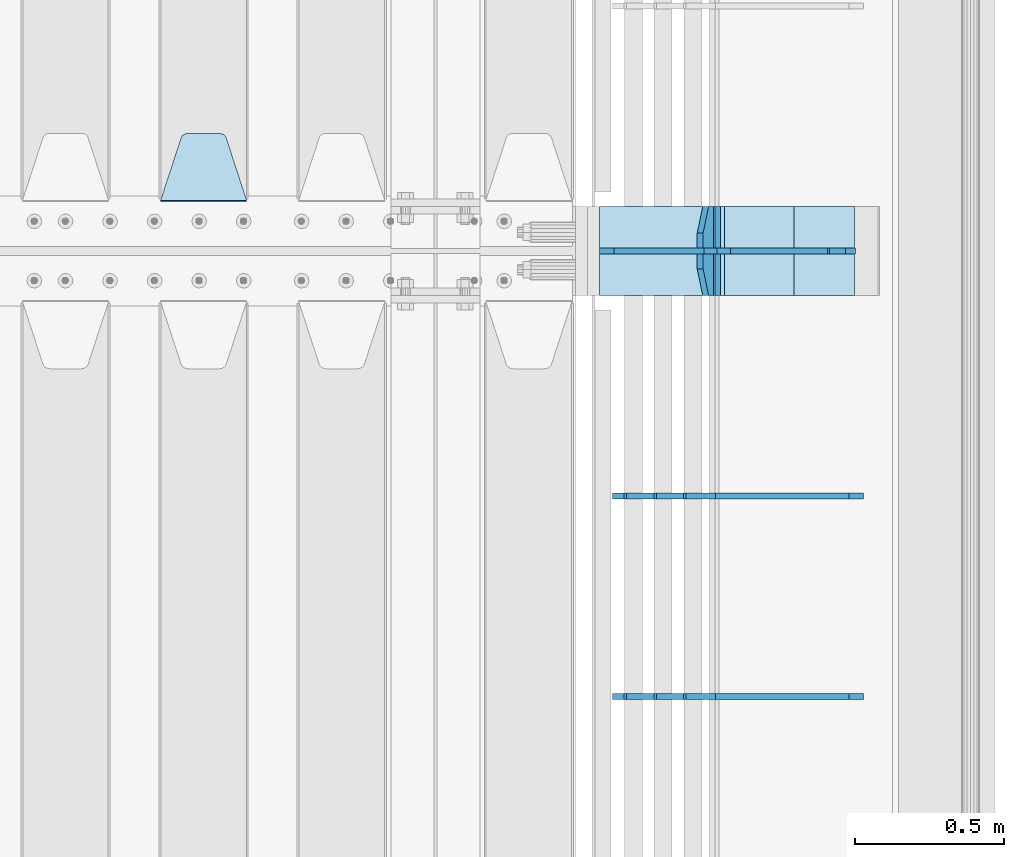
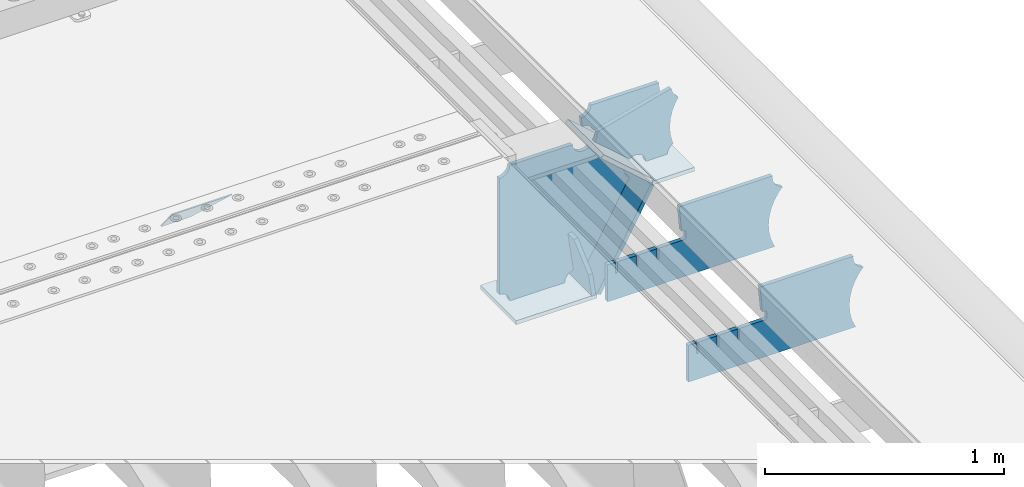
# One storey, part 240 of 257: 11 plates.
"""IFC2X3 building model written with IfcOpenShell, lengths in millimetres."""

from ifc_helpers import new_model, si_unit, frame, origin_with_axes, place, context, subcontext, project, spatial, faceted_brep, material, type_object, element, save


model = new_model("IFC2X3")

# Units and contexts
model_context = context("Model", 3, precision=1e-05, world=origin_with_axes())
body_context = subcontext(model_context, "Body", "Model", "MODEL_VIEW")
ifc_project = project(units=[si_unit("LENGTHUNIT", "METRE", prefix="MILLI"), si_unit("AREAUNIT", "SQUARE_METRE"), si_unit("VOLUMEUNIT", "CUBIC_METRE"), si_unit("MASSUNIT", "GRAM", prefix="KILO"), si_unit("TIMEUNIT", "SECOND"), si_unit("PLANEANGLEUNIT", "RADIAN"), si_unit("SOLIDANGLEUNIT", "STERADIAN"), si_unit("THERMODYNAMICTEMPERATUREUNIT", "DEGREE_CELSIUS"), si_unit("LUMINOUSINTENSITYUNIT", "LUMEN")], contexts=[model_context])

# Site, building, storey
site_placement = place(None, origin_with_axes())
site = spatial("IfcSite", under=ifc_project, at=site_placement, CompositionType="ELEMENT")
building_placement = place(site_placement, origin_with_axes())
building = spatial("IfcBuilding", under=site, at=building_placement, Name="Standard", CompositionType="ELEMENT")
storey_placement = place(building_placement, origin_with_axes())
storey = spatial("IfcBuildingStorey", under=building, at=storey_placement, Name="Undefined", CompositionType="ELEMENT", Elevation=0.0)

# Plates
ifc_material = material(Name="STEEL/S355N")
plate_type_1 = type_object("IfcPlateType", PredefinedType="NOTDEFINED")
plate_1_placement = place(storey_placement, frame((58160.0, 9168.23223304703, -1.76776695296758), z_axis=(0.0, 0.707106781186547, -0.707106781186548), x_axis=(-1.0, 0.0, 0.0)))
element("IfcPlate", 1, at=plate_1_placement, inside=storey, type_object=plate_type_1, material=ifc_material, context=body_context, shape_type="Brep", body=[
    faceted_brep([(0.0, -2.5, 0.0), (69.345504679477, -2.50000000000091, 300.17173142483), (69.345504679477, 2.5, 300.171731424831), (0.0, 2.5, 0.0), (70.927406119954, -2.50000000000091, 304.8974424154), (70.927406119954, 2.5, 304.8974424154), (73.3818627772271, -2.50000000000091, 309.234538108527), (73.3818627772271, 2.49999999999909, 309.234538108527), (76.6187032999587, -2.5, 313.023683126103), (76.6187032999587, 2.5, 313.023683126103), (80.5190132705029, -2.5, 316.125672595372), (80.5190132705029, 2.5, 316.125672595371), (84.9395038596849, -2.5, 318.426546230476), (84.9395038596849, 2.5, 318.426546230477), (89.7177759439219, -2.5, 319.841774983275), (89.7177759439219, 2.5, 319.841774983275), (94.6782862926484, -2.5, 320.319366455079), (94.6782862926484, 2.5, 320.319366455079), (195.321713707352, -2.5, 320.319366455079), (195.321713707352, 2.5, 320.319366455079), (200.282224056078, -2.5, 319.841774983275), (200.282224056078, 2.49999999999909, 319.841774983275), (205.060496140315, -2.5, 318.426546230476), (205.060496140315, 2.49999999999909, 318.426546230475), (209.480986729497, -2.5, 316.125672595371), (209.480986729497, 2.5, 316.125672595371), (213.381296700041, -2.50000000000091, 313.023683126102), (213.381296700041, 2.5, 313.023683126103), (216.618137222766, -2.50000000000091, 309.234538108527), (216.618137222766, 2.5, 309.234538108527), (219.072593880039, -2.5, 304.897442415399), (219.072593880039, 2.5, 304.897442415399), (220.654495320523, -2.50000000000091, 300.17173142483), (220.654495320523, 2.5, 300.171731424831), (290.0, -2.50000000000091, 0.0), (290.0, 2.5, 9.09494701772928e-13)], [[[0, 1, 2, 3]], [[1, 4, 5, 2]], [[4, 6, 7, 5]], [[6, 8, 9, 7]], [[8, 10, 11, 9]], [[10, 12, 13, 11]], [[12, 14, 15, 13]], [[14, 16, 17, 15]], [[16, 18, 19, 17]], [[18, 20, 21, 19]], [[20, 22, 23, 21]], [[22, 24, 25, 23]], [[24, 26, 27, 25]], [[26, 28, 29, 27]], [[28, 30, 31, 29]], [[30, 32, 33, 31]], [[32, 34, 35, 33]], [[34, 0, 3, 35]], [[5, 7, 9, 11, 13, 15, 17, 19, 21, 23, 25, 27, 29, 31, 33, 35, 3, 2]], [[34, 32, 30, 28, 26, 24, 22, 20, 18, 16, 14, 12, 10, 8, 6, 4, 1, 0]]]),
])
plate_type_2 = type_object("IfcPlateType", PredefinedType="NOTDEFINED")
plate_2_placement = place(storey_placement, frame((59721.0775331946, 9150.00000000169, -871.412303810021), z_axis=(0.0, -1.0, 0.0), x_axis=(-0.137902988002477, 0.0, 0.990445741017643)))
element("IfcPlate", 2, at=plate_2_placement, inside=storey, type_object=plate_type_2, material=ifc_material, context=body_context, shape_type="Brep", body=[
    faceted_brep([(0.0, -10.0, 0.0), (-2.00088834390044e-10, -10.0, 300.0), (-2.00088834390044e-10, 10.0, 300.0), (0.0, 10.0, 0.0), (114.999999999998, -10.0, 300.0), (115.0, 10.0, 300.0), (249.999999999998, -10.0, 210.0), (249.999999999998, 10.0, 210.0), (249.999999999998, -10.0, 90.0), (249.999999999998, 10.0, 90.0), (114.999999999998, -10.0, -1.10503606265411e-10), (115.0, 10.0, -1.10503606265411e-10)], [[[0, 1, 2, 3]], [[1, 4, 5, 2]], [[4, 6, 7, 5]], [[6, 8, 9, 7]], [[8, 10, 11, 9]], [[10, 0, 3, 11]], [[5, 7, 9, 11, 3, 2]], [[10, 8, 6, 4, 1, 0]]]),
])
plate_type_3 = type_object("IfcPlateType", PredefinedType="NOTDEFINED")
plate_3_placement = place(storey_placement, frame((59749.9988298913, 9000.00000000007, -179.999999999866), z_axis=(0.0, 0.0, -1.0), x_axis=(-1.0, 0.0, 0.0)))
element("IfcPlate", 3, at=plate_3_placement, inside=storey, type_object=plate_type_3, material=ifc_material, context=body_context, shape_type="Brep", body=[
    faceted_brep([(46.0258547361809, 10.0, 641.078828352491), (73.3015011075258, 10.0, 445.179898435806), (73.3015011075258, -10.0, 445.179898435806), (46.0258547361809, -10.0, 641.078828352491), (53.4925862871751, 10.0, 442.421838675757), (53.4925862871751, -10.0, 442.421838675757), (25.7820501124297, 10.0, 641.4442306713), (25.7820501124297, -10.0, 641.4442306713), (54.6652503111691, 10.0, 642.447174185377), (54.6652503111691, -10.0, 642.447174185377), (68.6036632070463, -10.0, 649.549150281387), (68.6036632070463, 10.0, 649.549150281387), (79.6652503111691, -10.0, 660.610737385511), (79.6652503111691, 10.0, 660.610737385511), (86.7672264071807, -10.0, 674.549150281387), (86.7672264071807, 10.0, 674.549150281387), (89.2144005924201, -10.0, 690.0), (89.2144005924201, 10.0, 690.0), (353.0, -10.0, 690.0), (353.0, 10.0, 690.0), (355.447174185239, -10.0, 674.549150281253), (355.447174185239, 10.0, 674.549150281253), (362.549150281251, -10.0, 660.610737385376), (362.549150281251, 10.0, 660.610737385376), (373.610737385374, -10.0, 649.549150281253), (373.610737385374, 10.0, 649.549150281253), (387.549150281251, -10.0, 642.447174185242), (387.549150281251, 10.0, 642.447174185242), (403.0, -10.0, 640.0), (403.0, 10.0, 640.0), (403.0, -10.0, 50.0), (403.0, 10.0, 50.0), (387.549150281251, -10.0, 47.5528258147577), (387.549150281251, 10.0, 47.5528258147577), (373.610737385374, -10.0, 40.4508497187474), (373.610737385374, 10.0, 40.4508497187474), (362.549150281251, -10.0, 29.3892626146236), (362.549150281251, 10.0, 29.3892626146236), (355.447174185239, -10.0, 15.4508497187474), (355.447174185239, 10.0, 15.4508497187474), (353.0, -10.0, 0.0), (353.0, 10.0, 0.0), (50.0, -10.0, 0.0), (50.0, 10.0, 0.0), (47.0349915316328, -10.0, 16.9620037619133), (47.0349915316328, 10.0, 16.9620037619133), (38.4916171352306, -10.0, 31.9123081320451), (38.4916171352306, 10.0, 31.9123081320451), (25.3831239081483, -10.0, 43.0778019479116), (25.3831239081483, 10.0, 43.0778019479116), (9.26418358741648, -10.0, 49.1342538608113), (9.26418358741648, 10.0, 49.1342538608113), (-7.95349204488593, -10.0, 49.363366622344), (-7.95349204488593, 10.0, 49.363366622344), (-24.2278808265401, -10.0, 43.7379673813837), (-24.2278808265401, 10.0, 43.7379673813837), (-37.6288347353475, -10.0, 32.9252303934259), (-37.6288347353475, 10.0, 32.9252303934259), (-210.371165264653, -10.0, 184.074769606574), (-210.371165264653, 10.0, 184.074769606574), (-202.382363280565, -10.0, 196.529747922069), (-202.382363280565, 10.0, 196.529747922069), (-198.388707244048, -10.0, 210.777489969227), (-198.388707244048, 10.0, 210.777489969227), (-198.73995746443, -10.0, 225.570193077959), (-198.73995746443, 10.0, 225.570193077959), (-203.40535180681, -10.0, 239.612327446012), (-203.40535180681, 10.0, 239.612327446012), (-211.976299808361, -10.0, 251.674097313455), (-211.976299808361, 10.0, 251.674097313455), (-223.702166612966, -10.0, 260.699145216992), (-223.702166612966, 10.0, 260.699145216992), (-9.29783338703419, -10.0, 646.300854783008), (-9.29783338703419, 10.0, 646.300854783008), (6.98069453598146, -10.0, 640.647282345602), (6.98069453598146, 10.0, 640.647282345602), (24.2117663163663, -10.0, 640.855891896051), (24.2117663163663, 10.0, 640.855891896051)], [[[0, 1, 2, 3]], [[4, 5, 2, 1]], [[6, 7, 5, 4]], [[8, 9, 10, 11]], [[11, 10, 12, 13]], [[13, 12, 14, 15]], [[15, 14, 16, 17]], [[18, 19, 17, 16]], [[18, 20, 21, 19]], [[20, 22, 23, 21]], [[22, 24, 25, 23]], [[24, 26, 27, 25]], [[26, 28, 29, 27]], [[28, 30, 31, 29]], [[30, 32, 33, 31]], [[32, 34, 35, 33]], [[34, 36, 37, 35]], [[36, 38, 39, 37]], [[38, 40, 41, 39]], [[40, 42, 43, 41]], [[42, 44, 45, 43]], [[44, 46, 47, 45]], [[46, 48, 49, 47]], [[48, 50, 51, 49]], [[50, 52, 53, 51]], [[52, 54, 55, 53]], [[54, 56, 57, 55]], [[56, 58, 59, 57]], [[58, 60, 61, 59]], [[60, 62, 63, 61]], [[62, 64, 65, 63]], [[64, 66, 67, 65]], [[66, 68, 69, 67]], [[68, 70, 71, 69]], [[70, 72, 73, 71]], [[72, 74, 75, 73]], [[74, 76, 77, 75]], [[1, 0, 8, 11, 13, 15, 17, 19, 21, 23, 25, 27, 29, 31, 33, 35, 37, 39, 41, 43, 45, 47, 49, 51, 53, 55, 57, 59, 61, 63, 65, 67, 69, 71, 73, 75, 77, 6, 4]], [[9, 8, 0, 3]], [[76, 74, 72, 70, 68, 66, 64, 62, 60, 58, 56, 54, 52, 50, 48, 46, 44, 42, 40, 38, 36, 34, 32, 30, 28, 26, 24, 22, 20, 18, 16, 14, 12, 10, 9, 3, 2, 5, 7]], [[77, 76, 7, 6]]]),
])
plate_type_4 = type_object("IfcPlateType", PredefinedType="NOTDEFINED")
plate_4_placement = place(storey_placement, frame((60285.9988298906, 9000.0, -9.99999999999716), z_axis=(0.0, 0.0, -1.0), x_axis=(-1.0, 0.0, 0.0)))
element("IfcPlate", 4, at=plate_4_placement, inside=storey, type_object=plate_type_4, material=ifc_material, context=body_context, shape_type="Brep", body=[
    faceted_brep([(164.157641141064, -10.0, 44.1844865875018), (486.71834084086, -10.0, 131.004562768382), (486.71834084086, 10.0, 131.004562768382), (164.157641141064, 10.0, 44.1844865875018), (492.179177700767, -10.0, 118.185717565315), (492.179177700767, 10.0, 118.185717565315), (500.965368826706, -10.0, 107.371542744776), (500.965368826706, 10.0, 107.371542744776), (512.394601349042, -10.0, 99.4018391429503), (512.394601349042, 10.0, 99.4018391429503), (525.579310641864, -10.0, 94.8955133209048), (525.579310641864, 10.0, 94.8955133209048), (539.495606295335, -10.0, 94.2025148824028), (539.495606295335, 10.0, 94.2025148824028), (543.504393704665, -10.0, 49.7974851175972), (543.504393704665, 10.0, 49.7974851175972), (529.167086307512, -10.0, 46.3176139481669), (529.167086307512, 10.0, 46.3176139481669), (516.469507120331, -10.0, 38.8049999196639), (516.469507120331, 10.0, 38.8049999196639), (506.517198234542, -10.0, 27.9137449599276), (506.517198234542, 10.0, 27.9137449599276), (500.17667886756, -10.0, 14.592119649441), (500.17667886756, 10.0, 14.592119649441), (498.0, -10.0, 0.0), (498.0, 10.0, 0.0), (170.0, -10.0, 0.0), (170.0, 10.0, 0.0), (169.632873911985, -10.0, 11.1663820622718), (169.632873911985, 10.0, 11.1663820622718), (168.533081313406, -10.0, 22.2845350637931), (168.533081313406, 10.0, 22.2845350637931), (166.705372351957, -10.0, 33.3064382514178), (166.705372351957, 10.0, 33.3064382514178)], [[[0, 1, 2, 3]], [[1, 4, 5, 2]], [[4, 6, 7, 5]], [[6, 8, 9, 7]], [[8, 10, 11, 9]], [[10, 12, 13, 11]], [[12, 14, 15, 13]], [[14, 16, 17, 15]], [[16, 18, 19, 17]], [[18, 20, 21, 19]], [[20, 22, 23, 21]], [[22, 24, 25, 23]], [[24, 26, 27, 25]], [[26, 28, 29, 27]], [[28, 30, 31, 29]], [[30, 32, 33, 31]], [[32, 0, 3, 33]], [[5, 7, 9, 11, 13, 15, 17, 19, 21, 23, 25, 27, 29, 31, 33, 3, 2]], [[32, 30, 28, 26, 24, 22, 20, 18, 16, 14, 12, 10, 8, 6, 4, 1, 0]]]),
])
plate_type_5 = type_object("IfcPlateType", PredefinedType="NOTDEFINED")
plate_5_placement = place(storey_placement, frame((60290.9988502512, 8999.99999999933, -28.9999913318487), z_axis=(0.260769276985653, 0.0, -0.965401151946889), x_axis=(-0.965401151946889, 0.0, -0.260769276985654)))
element("IfcPlate", 5, at=plate_5_placement, inside=storey, type_object=plate_type_5, material=ifc_material, context=body_context, shape_type="Brep", body=[
    faceted_brep([(183.436474692309, 10.0, 275.852500330426), (184.918388609047, 10.0, 264.417843531332), (184.918388609047, -10.0, 264.417843531332), (183.436474692309, -10.0, 275.852500330426), (183.794583267605, 10.0, 224.576469334614), (183.794583267605, -10.0, 224.576469334614), (176.452049775828, 10.0, 185.401410454628), (176.452049775828, -10.0, 185.401410454628), (163.071585676764, 10.0, 147.857286855564), (163.071585676764, -10.0, 147.857286855564), (143.982662403738, 10.0, 112.868559462235), (143.982662403738, -10.0, 112.868559462235), (119.65531260024, 10.0, 81.2967668639885), (119.65531260024, -10.0, 81.2967668639885), (100.960891712741, 10.0, 63.6280409830997), (100.960891712741, -10.0, 63.6280409830997), (194.486836975899, -10.0, 278.751956446691), (207.178624553366, -10.0, 286.65099493752), (207.178624553366, 10.0, 286.65099493752), (194.486836975899, 10.0, 278.751956446691), (216.968013469435, -10.0, 297.948965801401), (216.968013469435, 10.0, 297.948965801401), (222.979925232852, -10.0, 311.635937633771), (222.979925232852, 10.0, 311.635937633771), (323.381647032758, -10.0, 284.515917834988), (323.381647032758, 10.0, 284.515917834988), (321.720617177329, -10.0, 268.853198956864), (321.720617177329, 10.0, 268.853198956864), (325.01434448114, -10.0, 253.450889283185), (325.01434448114, 10.0, 253.450889283185), (332.935986082477, -10.0, 239.837389469556), (332.935986082477, 10.0, 239.837389469556), (344.699462330085, -10.0, 229.36359314694), (344.699462330085, 10.0, 229.36359314694), (359.1374609708, -10.0, 223.068835162203), (359.1374609708, 10.0, 223.068835162203), (374.817271777676, -10.0, 221.577756392893), (374.817271777676, 10.0, 221.577756392893), (390.182952880852, -10.0, 225.03833007813), (390.182952880852, 10.0, 225.03833007813), (512.909060513019, -10.0, 41.5599003357038), (512.909060513019, 10.0, 41.5599003357038), (503.648024844573, -10.0, 33.5643666747728), (503.648024844573, 10.0, 33.5643666747728), (496.6060645697, -10.0, 23.5590612990018), (496.6060645697, 10.0, 23.5590612990018), (492.204839143924, -10.0, 12.1430832451115), (492.204839143924, 10.0, 12.1430832451115), (490.707885742188, -10.0, 3.83806764148176e-10), (490.707885742188, 10.0, 3.83806764148176e-10), (119.999999999993, -10.0, 9.64064383879304e-11), (119.999999999993, 10.0, 9.64064383879304e-11), (117.226254779103, -10.0, 25.6516118492182), (117.226254779103, 10.0, 25.6516118492182), (109.033246825653, -10.0, 50.1173731021008), (109.033246825653, 10.0, 50.1173731021008)], [[[0, 1, 2, 3]], [[4, 5, 2, 1]], [[6, 7, 5, 4]], [[8, 9, 7, 6]], [[10, 11, 9, 8]], [[12, 13, 11, 10]], [[14, 15, 13, 12]], [[16, 17, 18, 19]], [[17, 20, 21, 18]], [[20, 22, 23, 21]], [[22, 24, 25, 23]], [[24, 26, 27, 25]], [[26, 28, 29, 27]], [[28, 30, 31, 29]], [[30, 32, 33, 31]], [[32, 34, 35, 33]], [[34, 36, 37, 35]], [[36, 38, 39, 37]], [[38, 40, 41, 39]], [[40, 42, 43, 41]], [[42, 44, 45, 43]], [[44, 46, 47, 45]], [[46, 48, 49, 47]], [[48, 50, 51, 49]], [[50, 52, 53, 51]], [[52, 54, 55, 53]], [[10, 8, 6, 4, 1, 0, 19, 18, 21, 23, 25, 27, 29, 31, 33, 35, 37, 39, 41, 43, 45, 47, 49, 51, 53, 55, 14, 12]], [[16, 19, 0, 3]], [[54, 52, 50, 48, 46, 44, 42, 40, 38, 36, 34, 32, 30, 28, 26, 24, 22, 20, 17, 16, 3, 2, 5, 7, 9, 11, 13, 15]], [[55, 54, 15, 14]]]),
])
plate_type_6 = type_object("IfcPlateType", PredefinedType="NOTDEFINED")
plate_6_placement = place(storey_placement, frame((59762.2260590443, 9149.99999999933, -177.219372761326), z_axis=(0.752414935148685, 0.0, -0.658689430130164), x_axis=(0.0, -1.0, 0.0)))
element("IfcPlate", 6, at=plate_6_placement, inside=storey, type_object=plate_type_6, material=ifc_material, context=body_context, shape_type="Brep", body=[
    faceted_brep([(0.0, -10.0, 0.0), (1.09139364212751e-10, -10.0000000000146, 319.999999999993), (1.09139364212751e-10, 9.99999999999272, 320.0), (0.0, 10.0, 0.0), (300.0, -10.0000000000146, 319.999999999993), (300.0, 9.99999999999272, 320.0), (300.0, -10.0000000000073, 5.82076609134674e-11), (300.0, 9.99999999999272, 5.82076609134674e-11)], [[[0, 1, 2, 3]], [[1, 4, 5, 2]], [[4, 6, 7, 5]], [[6, 0, 3, 7]], [[5, 7, 3, 2]], [[6, 4, 1, 0]]]),
])
plate_7_placement = place(storey_placement, frame((60003.0007288108, 9150.00000000007, -408.004820491625), z_axis=(-0.484064236150485, 0.0, -0.875032465272031), x_axis=(0.0, -1.0, 0.0)))
element("IfcPlate", 7, at=plate_7_placement, inside=storey, type_object=plate_type_6, material=ifc_material, context=body_context, shape_type="Brep", body=[
    faceted_brep([(0.0, -10.0, 0.0), (3.86515239370056e-07, -10.0, 533.528442382816), (3.86515239370056e-07, 10.0, 533.528442382813), (0.0, 10.0, 0.0), (300.003295898438, -10.0, 533.549133300781), (300.003295898438, 10.0, 533.549133300785), (300.0, -10.0000000000073, 5.82076609134674e-11), (300.0, 9.99999999999272, 5.82076609134674e-11)], [[[0, 1, 2, 3]], [[1, 4, 5, 2]], [[4, 6, 7, 5]], [[6, 0, 3, 7]], [[5, 7, 3, 2]], [[6, 4, 1, 0]]]),
])
plate_8_placement = place(storey_placement, frame((59346.9988298913, 9150.00000000007, -879.999999999866), z_axis=(0.0, -1.0, 0.0), x_axis=(1.0, 0.0, 0.0)))
element("IfcPlate", 8, at=plate_8_placement, inside=storey, type_object=plate_type_6, material=ifc_material, context=body_context, shape_type="Brep", body=[
    faceted_brep([(0.0, -10.0, 0.0), (-2.00088834390044e-10, -10.0, 300.0), (-2.00088834390044e-10, 10.0, 300.0), (0.0, 10.0, 0.0), (389.0, -10.0, 300.0), (389.0, 10.0, 300.0), (389.0, -10.0, 0.0), (389.0, 10.0, 0.0)], [[[0, 1, 2, 3]], [[1, 4, 5, 2]], [[4, 6, 7, 5]], [[6, 0, 3, 7]], [[5, 7, 3, 2]], [[6, 4, 1, 0]]]),
])
plate_type_7 = type_object("IfcPlateType", PredefinedType="NOTDEFINED")
plate_9_placement = place(storey_placement, frame((60206.9988298913, 9149.99999999933, -397.999999999763), z_axis=(-1.0, 0.0, 0.0), x_axis=(0.0, -1.0, 0.0)))
element("IfcPlate", 9, at=plate_9_placement, inside=storey, type_object=plate_type_7, material=ifc_material, context=body_context, shape_type="Brep", body=[
    faceted_brep([(0.0, -10.0, 0.0), (4.63842297904193e-10, -10.0, 204.0), (4.63842297904193e-10, 10.0, 204.0), (0.0, 10.0, 0.0), (300.0, -10.0, 204.0), (300.0, 10.0, 204.0), (300.0, -10.0000000000073, 5.82076609134674e-11), (300.0, 9.99999999999272, 5.82076609134674e-11)], [[[0, 1, 2, 3]], [[1, 4, 5, 2]], [[4, 6, 7, 5]], [[6, 0, 3, 7]], [[5, 7, 3, 2]], [[6, 4, 1, 0]]]),
])
plate_type_8 = type_object("IfcPlateType", PredefinedType="NOTDEFINED")
plate_10_placement = place(storey_placement, frame((60232.9182339676, 7499.99928283691, -374.002067436517), z_axis=(0.0, 0.0, 1.0), x_axis=(-1.0, 0.0, 0.0)))
element("IfcPlate", 10, at=plate_10_placement, inside=storey, type_object=plate_type_8, material=ifc_material, context=body_context, shape_type="Brep", body=[
    faceted_brep([(801.919404066546, -10.0, 188.0), (801.919404066546, 10.0, 188.0), (801.919404066546, 10.0, 132.002067436952), (801.919404066546, -10.0, 132.002067436952), (793.919404066546, 10.0, 132.002067436952), (793.919404066546, -10.0, 132.002067436952), (793.919404066546, 10.0, 180.002067436952), (793.919404066546, -10.0, 180.002067436952), (793.52785619691, 10.0, 182.474203391951), (793.52785619691, -10.0, 182.474203391951), (792.391540021548, 10.0, 184.704349455291), (792.391540021548, -10.0, 184.704349455291), (790.621686084887, 10.0, 186.474203391951), (790.621686084887, -10.0, 186.474203391951), (788.391540021548, 10.0, 187.610519567313), (788.391540021548, -10.0, 187.610519567313), (785.919404066546, -10.0, 188.002067436952), (785.919404066546, 10.0, 188.0), (841.0, -10.0, 188.0), (841.0, -10.0, 0.0), (841.0, 10.0, 0.0), (841.0, 10.0, 188.0), (33.3619566735943, -10.0, 0.0), (33.3619566735943, 10.0, 0.0), (36.2350612208102, -10.0, 4.68848050267013), (36.2350612208102, 10.0, 4.68848050267013), (51.4877592159319, -10.0, 41.5117508652784), (51.4877592159319, 10.0, 41.5117508652784), (60.7922425881334, -10.0, 80.2677133162964), (60.7922425881334, 10.0, 80.2677133162964), (63.9194040769653, -10.0, 120.002067436515), (63.9194040769653, 10.0, 120.002067436515), (60.7922425881334, -10.0, 159.736421556734), (60.7922425881334, 10.0, 159.736421556734), (51.4877592159319, -10.0, 198.492384007752), (51.4877592159319, 10.0, 198.492384007752), (36.2350612208102, -10.0, 235.31565437036), (36.2350612208102, 10.0, 235.31565437036), (15.4097206482038, -10.0, 269.299521518803), (15.4097206482038, 10.0, 269.299521518803), (-3.35474438100209, -10.0, 291.269887256574), (-3.35474438100209, 10.0, 291.269887256574), (-2.36881039375294, -10.0000000000001, 291.426043859339), (-2.36881039375294, 10.0, 291.426043859339), (17.1449676604752, -10.0000000000001, 301.368810393754), (17.1449676604752, 10.0, 301.368810393754), (32.6311896062471, -10.0000000000001, 316.855032339527), (32.6311896062471, 10.0, 316.855032339527), (42.573956140659, -10.0000000000001, 336.368810393754), (42.573956140659, 10.0, 336.368810393754), (46.0, -10.0000000000001, 358.0), (46.0, 10.0, 358.0), (45.0495205499174, -10.0, 364.001091067617), (45.0495205499174, 10.0, 364.001091067617), (495.040008544922, -10.0, 364.010009765625), (495.040008544922, 10.0, 364.010009765625), (483.600036621094, -10.0, 233.759994506836), (483.600036621094, 10.0, 233.759994506836), (472.0, -10.0, 233.759994506836), (472.0, 10.0, 233.759994506836), (468.909830056247, -10.0, 233.270559669787), (468.909830056247, 10.0, 233.270559669787), (466.122147477072, -10.0, 231.850164450585), (466.122147477072, 10.0, 231.850164450585), (463.909830056247, -10.0, 229.637847029761), (463.909830056247, 10.0, 229.637847029761), (462.489434837051, -10.0, 226.850164450585), (462.489434837051, 10.0, 226.850164450585), (462.0, -10.0, 223.759994506836), (462.0, 10.0, 223.759994506836), (462.0, -10.0, 198.0), (462.0, 10.0, 198.0), (462.489434837051, -10.0, 194.909830056251), (462.489434837051, 10.0, 194.909830056251), (463.909830056247, -10.0, 192.122147477075), (463.909830056247, 10.0, 192.122147477075), (466.122147477072, -10.0, 189.909830056251), (466.122147477072, 10.0, 189.909830056251), (468.909830056247, -10.0, 188.489434837048), (468.909830056247, 10.0, 188.489434837048), (472.0, -10.0, 188.0), (472.0, 10.0, 188.0), (585.919404066546, -10.0, 188.002067436952), (585.919404066546, 10.0, 188.0), (588.391540021548, -10.0, 187.610519567313), (588.391540021548, 10.0, 187.610519567313), (590.621686084887, -10.0, 186.474203391951), (590.621686084887, 10.0, 186.474203391951), (592.391540021548, -10.0, 184.704349455291), (592.391540021548, 10.0, 184.704349455291), (593.52785619691, -10.0, 182.474203391951), (593.52785619691, 10.0, 182.474203391951), (593.919404066546, -10.0, 180.002067436952), (593.919404066546, 10.0, 180.002067436952), (593.919404066546, -10.0, 132.002067436952), (593.919404066546, 10.0, 132.002067436952), (601.919404066546, -10.0, 132.002067436952), (601.919404066546, 10.0, 132.002067436952), (601.919404066546, -10.0, 188.0), (601.919404066546, 10.0, 188.0), (685.919404066546, -10.0, 188.002067436952), (685.919404066546, 10.0, 188.0), (688.391540021548, -9.99999999999977, 187.610519567313), (688.391540021548, 10.0, 187.610519567313), (690.621686084887, -9.99999999999977, 186.474203391951), (690.621686084887, 10.0, 186.474203391951), (692.391540021548, -9.99999999999977, 184.704349455291), (692.391540021548, 10.0, 184.704349455291), (693.52785619691, -9.99999999999977, 182.474203391951), (693.52785619691, 10.0, 182.474203391951), (693.919404066546, -9.99999999999977, 180.002067436952), (693.919404066546, 10.0, 180.002067436952), (693.919404066546, -9.99999999999977, 132.002067436952), (693.919404066546, 10.0, 132.002067436952), (701.919404066546, -9.99999999999977, 132.002067436952), (701.919404066546, 10.0, 132.002067436952), (701.919404066546, -10.0, 188.0), (701.919404066546, 10.0, 188.0)], [[[0, 1, 2, 3]], [[3, 2, 4, 5]], [[5, 4, 6, 7]], [[7, 6, 8, 9]], [[9, 8, 10, 11]], [[11, 10, 12, 13]], [[13, 12, 14, 15]], [[16, 15, 14, 17]], [[18, 19, 20, 21]], [[20, 19, 22, 23]], [[22, 24, 25, 23]], [[26, 27, 25, 24]], [[28, 29, 27, 26]], [[30, 31, 29, 28]], [[32, 33, 31, 30]], [[34, 35, 33, 32]], [[36, 37, 35, 34]], [[38, 39, 37, 36]], [[39, 38, 40, 41]], [[40, 42, 43, 41]], [[44, 45, 43, 42]], [[46, 47, 45, 44]], [[48, 49, 47, 46]], [[50, 51, 49, 48]], [[52, 53, 51, 50]], [[54, 55, 53, 52]], [[54, 56, 57, 55]], [[56, 58, 59, 57]], [[58, 60, 61, 59]], [[60, 62, 63, 61]], [[62, 64, 65, 63]], [[64, 66, 67, 65]], [[66, 68, 69, 67]], [[68, 70, 71, 69]], [[70, 72, 73, 71]], [[72, 74, 75, 73]], [[74, 76, 77, 75]], [[76, 78, 79, 77]], [[78, 80, 81, 79]], [[81, 80, 82, 83]], [[82, 84, 85, 83]], [[86, 87, 85, 84]], [[88, 89, 87, 86]], [[90, 91, 89, 88]], [[92, 93, 91, 90]], [[94, 95, 93, 92]], [[96, 97, 95, 94]], [[98, 99, 97, 96]], [[99, 98, 100, 101]], [[100, 102, 103, 101]], [[104, 105, 103, 102]], [[106, 107, 105, 104]], [[108, 109, 107, 106]], [[110, 111, 109, 108]], [[112, 113, 111, 110]], [[114, 115, 113, 112]], [[116, 117, 115, 114]], [[117, 116, 16, 17]], [[12, 10, 8, 6, 4, 2, 1, 21, 20, 23, 25, 27, 29, 31, 33, 35, 37, 39, 41, 43, 45, 47, 49, 51, 53, 55, 57, 59, 61, 63, 65, 67, 69, 71, 73, 75, 77, 79, 81, 83, 85, 87, 89, 91, 93, 95, 97, 99, 101, 103, 105, 107, 109, 111, 113, 115, 117, 17, 14]], [[18, 21, 1, 0]], [[116, 114, 112, 110, 108, 106, 104, 102, 100, 98, 96, 94, 92, 90, 88, 86, 84, 82, 80, 78, 76, 74, 72, 70, 68, 66, 64, 62, 60, 58, 56, 54, 52, 50, 48, 46, 44, 42, 40, 38, 36, 34, 32, 30, 28, 26, 24, 22, 19, 18, 0, 3, 5, 7, 9, 11, 13, 15, 16]]]),
])
plate_11_placement = place(storey_placement, frame((60232.9182339676, 8174.99928283691, -374.002067436516), z_axis=(0.0, 0.0, 1.0), x_axis=(-1.0, 0.0, 0.0)))
element("IfcPlate", 11, at=plate_11_placement, inside=storey, type_object=plate_type_8, material=ifc_material, context=body_context, shape_type="Brep", body=[
    faceted_brep([(801.919404066546, -10.0, 188.0), (801.919404066546, 10.0, 188.0), (801.919404066546, 10.0, 132.002067436952), (801.919404066546, -10.0, 132.002067436952), (793.919404066546, 10.0, 132.002067436952), (793.919404066546, -10.0, 132.002067436952), (793.919404066546, 10.0, 180.002067436952), (793.919404066546, -10.0, 180.002067436952), (793.52785619691, 10.0, 182.474203391951), (793.52785619691, -10.0, 182.474203391951), (792.391540021548, 10.0, 184.704349455291), (792.391540021548, -10.0, 184.704349455291), (790.621686084887, 10.0, 186.474203391951), (790.621686084887, -10.0, 186.474203391951), (788.391540021548, 10.0, 187.610519567313), (788.391540021548, -10.0, 187.610519567313), (785.919404066546, -10.0, 188.002067436952), (785.919404066546, 10.0, 188.0), (841.0, -10.0, 188.0), (841.0, -10.0, 0.0), (841.0, 10.0, 0.0), (841.0, 10.0, 188.0), (33.3619566735943, -10.0, 0.0), (33.3619566735943, 10.0, 0.0), (36.2350612208102, -10.0, 4.68848050267013), (36.2350612208102, 10.0, 4.68848050267013), (51.4877592159319, -10.0, 41.5117508652784), (51.4877592159319, 10.0, 41.5117508652784), (60.7922425881334, -10.0, 80.2677133162964), (60.7922425881334, 10.0, 80.2677133162964), (63.9194040769653, -10.0, 120.002067436515), (63.9194040769653, 10.0, 120.002067436515), (60.7922425881334, -10.0, 159.736421556734), (60.7922425881334, 10.0, 159.736421556734), (51.4877592159319, -10.0, 198.492384007752), (51.4877592159319, 10.0, 198.492384007752), (36.2350612208102, -10.0, 235.31565437036), (36.2350612208102, 10.0, 235.31565437036), (15.4097206482038, -10.0, 269.299521518803), (15.4097206482038, 10.0, 269.299521518803), (-3.35474438100209, -10.0, 291.269887256574), (-3.35474438100209, 10.0, 291.269887256574), (-2.36881039375294, -10.0000000000001, 291.426043859339), (-2.36881039375294, 10.0, 291.426043859339), (17.1449676604752, -10.0000000000001, 301.368810393754), (17.1449676604752, 10.0, 301.368810393754), (32.6311896062471, -10.0000000000001, 316.855032339527), (32.6311896062471, 10.0, 316.855032339527), (42.573956140659, -10.0000000000001, 336.368810393754), (42.573956140659, 10.0, 336.368810393754), (46.0, -10.0000000000001, 358.0), (46.0, 10.0, 358.0), (45.0495205499174, -10.0, 364.001091067617), (45.0495205499174, 10.0, 364.001091067617), (495.040008544922, -10.0, 364.010009765625), (495.040008544922, 10.0, 364.010009765625), (483.600036621094, -10.0, 233.759994506836), (483.600036621094, 10.0, 233.759994506836), (472.0, -10.0, 233.759994506836), (472.0, 10.0, 233.759994506836), (468.909830056247, -10.0, 233.270559669787), (468.909830056247, 10.0, 233.270559669787), (466.122147477072, -10.0, 231.850164450585), (466.122147477072, 10.0, 231.850164450585), (463.909830056247, -10.0, 229.637847029761), (463.909830056247, 10.0, 229.637847029761), (462.489434837051, -10.0, 226.850164450585), (462.489434837051, 10.0, 226.850164450585), (462.0, -10.0, 223.759994506836), (462.0, 10.0, 223.759994506836), (462.0, -10.0, 198.0), (462.0, 10.0, 198.0), (462.489434837051, -10.0, 194.909830056251), (462.489434837051, 10.0, 194.909830056251), (463.909830056247, -10.0, 192.122147477075), (463.909830056247, 10.0, 192.122147477075), (466.122147477072, -10.0, 189.909830056251), (466.122147477072, 10.0, 189.909830056251), (468.909830056247, -10.0, 188.489434837048), (468.909830056247, 10.0, 188.489434837048), (472.0, -10.0, 188.0), (472.0, 10.0, 188.0), (585.919404066546, -10.0, 188.002067436952), (585.919404066546, 10.0, 188.0), (588.391540021548, -10.0, 187.610519567313), (588.391540021548, 10.0, 187.610519567313), (590.621686084887, -10.0, 186.474203391951), (590.621686084887, 10.0, 186.474203391951), (592.391540021548, -10.0, 184.704349455291), (592.391540021548, 10.0, 184.704349455291), (593.52785619691, -10.0, 182.474203391951), (593.52785619691, 10.0, 182.474203391951), (593.919404066546, -10.0, 180.002067436952), (593.919404066546, 10.0, 180.002067436952), (593.919404066546, -10.0, 132.002067436952), (593.919404066546, 10.0, 132.002067436952), (601.919404066546, -10.0, 132.002067436952), (601.919404066546, 10.0, 132.002067436952), (601.919404066546, -10.0, 188.0), (601.919404066546, 10.0, 188.0), (685.919404066546, -10.0, 188.002067436952), (685.919404066546, 10.0, 188.0), (688.391540021548, -9.99999999999977, 187.610519567313), (688.391540021548, 10.0, 187.610519567313), (690.621686084887, -9.99999999999977, 186.474203391951), (690.621686084887, 10.0, 186.474203391951), (692.391540021548, -9.99999999999977, 184.704349455291), (692.391540021548, 10.0, 184.704349455291), (693.52785619691, -9.99999999999977, 182.474203391951), (693.52785619691, 10.0, 182.474203391951), (693.919404066546, -9.99999999999977, 180.002067436952), (693.919404066546, 10.0, 180.002067436952), (693.919404066546, -9.99999999999977, 132.002067436952), (693.919404066546, 10.0, 132.002067436952), (701.919404066546, -9.99999999999977, 132.002067436952), (701.919404066546, 10.0, 132.002067436952), (701.919404066546, -10.0, 188.0), (701.919404066546, 10.0, 188.0)], [[[0, 1, 2, 3]], [[3, 2, 4, 5]], [[5, 4, 6, 7]], [[7, 6, 8, 9]], [[9, 8, 10, 11]], [[11, 10, 12, 13]], [[13, 12, 14, 15]], [[16, 15, 14, 17]], [[18, 19, 20, 21]], [[20, 19, 22, 23]], [[22, 24, 25, 23]], [[26, 27, 25, 24]], [[28, 29, 27, 26]], [[30, 31, 29, 28]], [[32, 33, 31, 30]], [[34, 35, 33, 32]], [[36, 37, 35, 34]], [[38, 39, 37, 36]], [[39, 38, 40, 41]], [[40, 42, 43, 41]], [[44, 45, 43, 42]], [[46, 47, 45, 44]], [[48, 49, 47, 46]], [[50, 51, 49, 48]], [[52, 53, 51, 50]], [[54, 55, 53, 52]], [[54, 56, 57, 55]], [[56, 58, 59, 57]], [[58, 60, 61, 59]], [[60, 62, 63, 61]], [[62, 64, 65, 63]], [[64, 66, 67, 65]], [[66, 68, 69, 67]], [[68, 70, 71, 69]], [[70, 72, 73, 71]], [[72, 74, 75, 73]], [[74, 76, 77, 75]], [[76, 78, 79, 77]], [[78, 80, 81, 79]], [[81, 80, 82, 83]], [[82, 84, 85, 83]], [[86, 87, 85, 84]], [[88, 89, 87, 86]], [[90, 91, 89, 88]], [[92, 93, 91, 90]], [[94, 95, 93, 92]], [[96, 97, 95, 94]], [[98, 99, 97, 96]], [[99, 98, 100, 101]], [[100, 102, 103, 101]], [[104, 105, 103, 102]], [[106, 107, 105, 104]], [[108, 109, 107, 106]], [[110, 111, 109, 108]], [[112, 113, 111, 110]], [[114, 115, 113, 112]], [[116, 117, 115, 114]], [[117, 116, 16, 17]], [[12, 10, 8, 6, 4, 2, 1, 21, 20, 23, 25, 27, 29, 31, 33, 35, 37, 39, 41, 43, 45, 47, 49, 51, 53, 55, 57, 59, 61, 63, 65, 67, 69, 71, 73, 75, 77, 79, 81, 83, 85, 87, 89, 91, 93, 95, 97, 99, 101, 103, 105, 107, 109, 111, 113, 115, 117, 17, 14]], [[18, 21, 1, 0]], [[116, 114, 112, 110, 108, 106, 104, 102, 100, 98, 96, 94, 92, 90, 88, 86, 84, 82, 80, 78, 76, 74, 72, 70, 68, 66, 64, 62, 60, 58, 56, 54, 52, 50, 48, 46, 44, 42, 40, 38, 36, 34, 32, 30, 28, 26, 24, 22, 19, 18, 0, 3, 5, 7, 9, 11, 13, 15, 16]]]),
])

save(model, "model.ifc")
